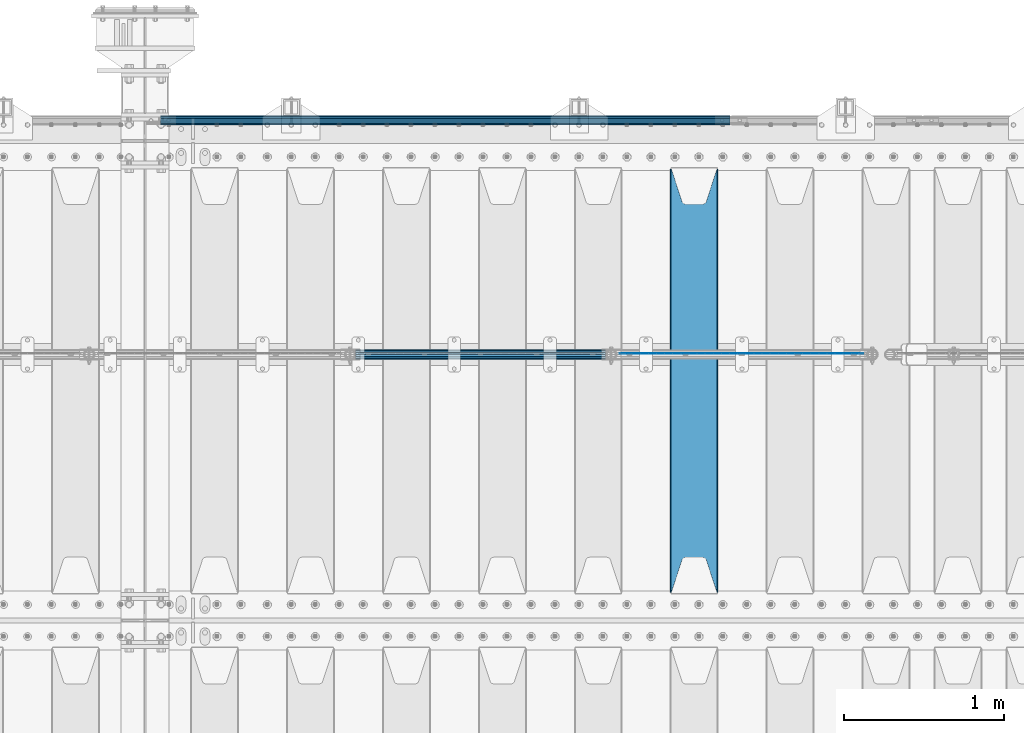
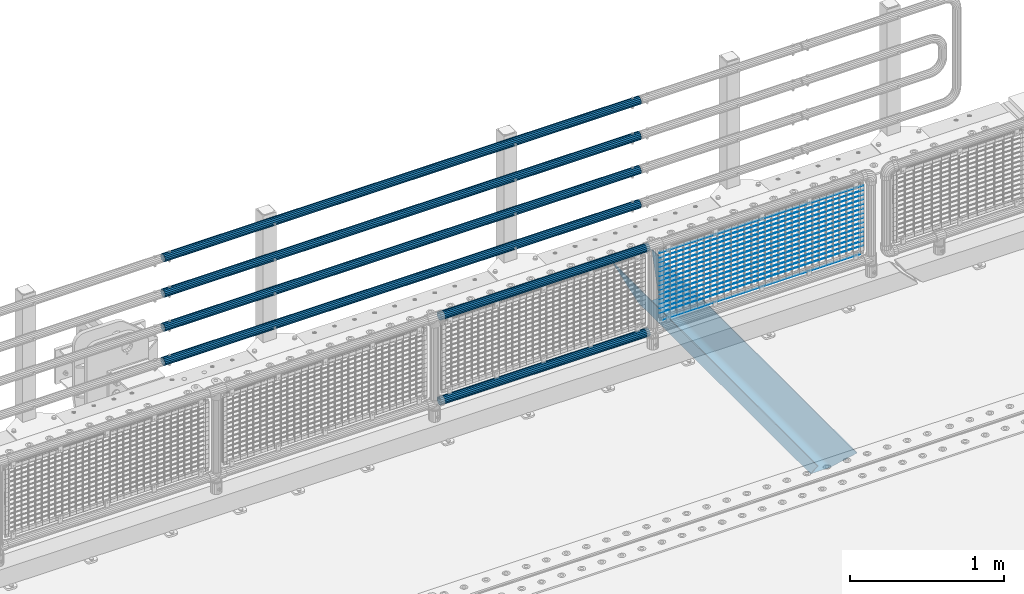
# One storey, part 146 of 270: 22 beams.
"""IFC2X3 building model written with IfcOpenShell, lengths in millimetres."""

from ifc_helpers import new_model, si_unit, frame, origin_with_axes, place, context, subcontext, project, spatial, faceted_brep, material, type_object, element, save


model = new_model("IFC2X3")

# Units and contexts
model_context = context("Model", 3, precision=1e-05, world=origin_with_axes())
body_context = subcontext(model_context, "Body", "Model", "MODEL_VIEW")
ifc_project = project(units=[si_unit("LENGTHUNIT", "METRE", prefix="MILLI"), si_unit("AREAUNIT", "SQUARE_METRE"), si_unit("VOLUMEUNIT", "CUBIC_METRE"), si_unit("MASSUNIT", "GRAM", prefix="KILO"), si_unit("TIMEUNIT", "SECOND"), si_unit("PLANEANGLEUNIT", "RADIAN"), si_unit("SOLIDANGLEUNIT", "STERADIAN"), si_unit("THERMODYNAMICTEMPERATUREUNIT", "DEGREE_CELSIUS"), si_unit("LUMINOUSINTENSITYUNIT", "LUMEN")], contexts=[model_context])

# Site, building, storey
site_placement = place(None, origin_with_axes())
site = spatial("IfcSite", under=ifc_project, at=site_placement, CompositionType="ELEMENT")
building_placement = place(site_placement, origin_with_axes())
building = spatial("IfcBuilding", under=site, at=building_placement, Name="Standard", CompositionType="ELEMENT")
storey_placement = place(building_placement, origin_with_axes())
storey = spatial("IfcBuildingStorey", under=building, at=storey_placement, Name="Undefined", CompositionType="ELEMENT", Elevation=0.0)

# Beams
ifc_material_1 = material()
beam_type_1 = type_object("IfcBeamType", PredefinedType="NOTDEFINED")
beam_1_placement = place(storey_placement, frame((17694.9999999999, -14870.1499999998, 149.849999999726), z_axis=(0.0, 0.0, -1.0), x_axis=(-1.0, 0.0, 0.0)))
element("IfcBeam", 1, at=beam_1_placement, inside=storey, type_object=beam_type_1, material=ifc_material_1, context=body_context, shape_type="Brep", body=[
    faceted_brep([(0.0, -26.5499999999993, 0.0), (0.0, -24.5290015881747, 10.1602451292931), (3563.0, -24.5290015881747, 10.1602451292931), (3563.0, -26.5499999999993, 0.0), (0.0, -18.7736850405036, 18.7736850405028), (3563.0, -18.7736850405036, 18.7736850405028), (0.0, -10.1602451292929, 24.5290015881747), (3563.0, -10.1602451292929, 24.5290015881747), (0.0, 0.0, 26.55), (3563.0, 0.0, 26.55), (0.0, 10.1602451292929, 24.5290015881747), (3563.0, 10.1602451292929, 24.5290015881747), (0.0, 18.7736850405036, 18.7736850405028), (3563.0, 18.7736850405036, 18.7736850405028), (0.0, 24.5290015881747, 10.1602451292931), (3563.0, 24.5290015881747, 10.1602451292931), (0.0, 26.5499999999993, 0.0), (3563.0, 26.5499999999993, 0.0), (0.0, 24.5290015881747, -10.1602451292931), (3563.0, 24.5290015881747, -10.1602451292931), (0.0, 18.7736850405036, -18.7736850405028), (3563.0, 18.7736850405036, -18.7736850405028), (0.0, 10.1602451292929, -24.5290015881747), (3563.0, 10.1602451292929, -24.5290015881747), (0.0, 0.0, -26.55), (3563.0, 0.0, -26.55), (0.0, -10.1602451292929, -24.5290015881747), (3563.0, -10.1602451292929, -24.5290015881747), (0.0, -18.7736850405036, -18.7736850405028), (3563.0, -18.7736850405036, -18.7736850405028), (0.0, -24.5290015881747, -10.1602451292931), (3563.0, -24.5290015881747, -10.1602451292931), (0.0, -30.1499999999996, 0.0), (0.0, -27.8549679052157, -11.5379054858058), (3563.0, -27.8549679052157, -11.5379054858075), (3563.0, -30.1499999999996, 0.0), (0.0, -21.3192694527752, -21.3192694527752), (3563.0, -21.3192694527752, -21.3192694527744), (0.0, -11.5379054858076, -27.8549679052157), (3563.0, -11.5379054858076, -27.8549679052153), (0.0, 0.0, -30.1500000000015), (3563.0, 0.0, -30.15), (0.0, 11.5379054858076, -27.8549679052157), (3563.0, 11.5379054858076, -27.8549679052153), (0.0, 21.3192694527752, -21.3192694527752), (3563.0, 21.3192694527752, -21.3192694527744), (0.0, 27.8549679052157, -11.5379054858058), (3563.0, 27.8549679052157, -11.5379054858074), (0.0, 30.1499999999996, 0.0), (3563.0, 30.1499999999996, 0.0), (0.0, 27.8549679052157, 11.5379054858058), (3563.0, 27.8549679052157, 11.5379054858075), (0.0, 21.3192694527752, 21.3192694527752), (3563.0, 21.3192694527752, 21.3192694527744), (0.0, 11.5379054858076, 27.8549679052157), (3563.0, 11.5379054858076, 27.8549679052153), (0.0, 0.0, 30.1500000000015), (3563.0, 0.0, 30.15), (0.0, -11.5379054858076, 27.8549679052157), (3563.0, -11.5379054858076, 27.8549679052153), (0.0, -21.3192694527752, 21.3192694527752), (3563.0, -21.3192694527752, 21.3192694527744), (0.0, -27.8549679052157, 11.5379054858058), (3563.0, -27.8549679052157, 11.5379054858075)], [[[0, 1, 2, 3]], [[1, 4, 5, 2]], [[4, 6, 7, 5]], [[6, 8, 9, 7]], [[8, 10, 11, 9]], [[10, 12, 13, 11]], [[12, 14, 15, 13]], [[14, 16, 17, 15]], [[16, 18, 19, 17]], [[18, 20, 21, 19]], [[20, 22, 23, 21]], [[22, 24, 25, 23]], [[24, 26, 27, 25]], [[26, 28, 29, 27]], [[28, 30, 31, 29]], [[30, 0, 3, 31]], [[32, 33, 34, 35]], [[33, 36, 37, 34]], [[36, 38, 39, 37]], [[38, 40, 41, 39]], [[40, 42, 43, 41]], [[42, 44, 45, 43]], [[44, 46, 47, 45]], [[46, 48, 49, 47]], [[48, 50, 51, 49]], [[50, 52, 53, 51]], [[52, 54, 55, 53]], [[54, 56, 57, 55]], [[56, 58, 59, 57]], [[58, 60, 61, 59]], [[60, 62, 63, 61]], [[62, 32, 35, 63]], [[37, 39, 41, 43, 45, 47, 49, 51, 53, 55, 57, 59, 61, 63, 35, 34], [5, 7, 9, 11, 13, 15, 17, 19, 21, 23, 25, 27, 29, 31, 3, 2]], [[62, 60, 58, 56, 54, 52, 50, 48, 46, 44, 42, 40, 38, 36, 33, 32], [30, 28, 26, 24, 22, 20, 18, 16, 14, 12, 10, 8, 6, 4, 1, 0]]]),
])
beam_2_placement = place(storey_placement, frame((17694.9999999999, -14870.1499999998, 420.149999999725), z_axis=(0.0, 0.0, -1.0), x_axis=(-1.0, 0.0, 0.0)))
element("IfcBeam", 2, at=beam_2_placement, inside=storey, type_object=beam_type_1, material=ifc_material_1, context=body_context, shape_type="Brep", body=[
    faceted_brep([(0.0, -26.5499999999993, 0.0), (0.0, -24.5290015881747, 10.1602451292931), (3563.0, -24.5290015881747, 10.1602451292931), (3563.0, -26.5499999999993, 0.0), (0.0, -18.7736850405036, 18.7736850405028), (3563.0, -18.7736850405036, 18.7736850405028), (0.0, -10.1602451292929, 24.5290015881747), (3563.0, -10.1602451292929, 24.5290015881747), (0.0, 0.0, 26.55), (3563.0, 0.0, 26.55), (0.0, 10.1602451292929, 24.5290015881747), (3563.0, 10.1602451292929, 24.5290015881747), (0.0, 18.7736850405036, 18.7736850405028), (3563.0, 18.7736850405036, 18.7736850405028), (0.0, 24.5290015881747, 10.1602451292931), (3563.0, 24.5290015881747, 10.1602451292931), (0.0, 26.5499999999993, 0.0), (3563.0, 26.5499999999993, 0.0), (0.0, 24.5290015881747, -10.1602451292931), (3563.0, 24.5290015881747, -10.1602451292931), (0.0, 18.7736850405036, -18.7736850405028), (3563.0, 18.7736850405036, -18.7736850405028), (0.0, 10.1602451292929, -24.5290015881747), (3563.0, 10.1602451292929, -24.5290015881747), (0.0, 0.0, -26.55), (3563.0, 0.0, -26.55), (0.0, -10.1602451292929, -24.5290015881747), (3563.0, -10.1602451292929, -24.5290015881747), (0.0, -18.7736850405036, -18.7736850405028), (3563.0, -18.7736850405036, -18.7736850405028), (0.0, -24.5290015881747, -10.1602451292931), (3563.0, -24.5290015881747, -10.1602451292931), (0.0, -30.1499999999996, 0.0), (0.0, -27.8549679052157, -11.5379054858058), (3563.0, -27.8549679052157, -11.5379054858075), (3563.0, -30.1499999999996, 0.0), (0.0, -21.3192694527752, -21.3192694527752), (3563.0, -21.3192694527752, -21.3192694527744), (0.0, -11.5379054858076, -27.8549679052157), (3563.0, -11.5379054858076, -27.8549679052153), (0.0, 0.0, -30.1500000000015), (3563.0, 0.0, -30.15), (0.0, 11.5379054858076, -27.8549679052157), (3563.0, 11.5379054858076, -27.8549679052153), (0.0, 21.3192694527752, -21.3192694527752), (3563.0, 21.3192694527752, -21.3192694527744), (0.0, 27.8549679052157, -11.5379054858058), (3563.0, 27.8549679052157, -11.5379054858074), (0.0, 30.1499999999996, 0.0), (3563.0, 30.1499999999996, 0.0), (0.0, 27.8549679052157, 11.5379054858058), (3563.0, 27.8549679052157, 11.5379054858075), (0.0, 21.3192694527752, 21.3192694527752), (3563.0, 21.3192694527752, 21.3192694527744), (0.0, 11.5379054858076, 27.8549679052157), (3563.0, 11.5379054858076, 27.8549679052153), (0.0, 0.0, 30.1500000000015), (3563.0, 0.0, 30.15), (0.0, -11.5379054858076, 27.8549679052157), (3563.0, -11.5379054858076, 27.8549679052153), (0.0, -21.3192694527752, 21.3192694527752), (3563.0, -21.3192694527752, 21.3192694527744), (0.0, -27.8549679052157, 11.5379054858058), (3563.0, -27.8549679052157, 11.5379054858075)], [[[0, 1, 2, 3]], [[1, 4, 5, 2]], [[4, 6, 7, 5]], [[6, 8, 9, 7]], [[8, 10, 11, 9]], [[10, 12, 13, 11]], [[12, 14, 15, 13]], [[14, 16, 17, 15]], [[16, 18, 19, 17]], [[18, 20, 21, 19]], [[20, 22, 23, 21]], [[22, 24, 25, 23]], [[24, 26, 27, 25]], [[26, 28, 29, 27]], [[28, 30, 31, 29]], [[30, 0, 3, 31]], [[32, 33, 34, 35]], [[33, 36, 37, 34]], [[36, 38, 39, 37]], [[38, 40, 41, 39]], [[40, 42, 43, 41]], [[42, 44, 45, 43]], [[44, 46, 47, 45]], [[46, 48, 49, 47]], [[48, 50, 51, 49]], [[50, 52, 53, 51]], [[52, 54, 55, 53]], [[54, 56, 57, 55]], [[56, 58, 59, 57]], [[58, 60, 61, 59]], [[60, 62, 63, 61]], [[62, 32, 35, 63]], [[37, 39, 41, 43, 45, 47, 49, 51, 53, 55, 57, 59, 61, 63, 35, 34], [5, 7, 9, 11, 13, 15, 17, 19, 21, 23, 25, 27, 29, 31, 3, 2]], [[62, 60, 58, 56, 54, 52, 50, 48, 46, 44, 42, 40, 38, 36, 33, 32], [30, 28, 26, 24, 22, 20, 18, 16, 14, 12, 10, 8, 6, 4, 1, 0]]]),
])
beam_3_placement = place(storey_placement, frame((17694.9999999999, -14870.1499999998, 969.849999999726), z_axis=(0.0, 0.0, -1.0), x_axis=(-1.0, 0.0, 0.0)))
element("IfcBeam", 3, at=beam_3_placement, inside=storey, type_object=beam_type_1, material=ifc_material_1, context=body_context, shape_type="Brep", body=[
    faceted_brep([(0.0, -26.5499999999993, 0.0), (0.0, -24.5290015881747, 10.1602451292931), (3563.0, -24.5290015881747, 10.1602451292931), (3563.0, -26.5499999999993, 0.0), (0.0, -18.7736850405036, 18.7736850405028), (3563.0, -18.7736850405036, 18.7736850405028), (0.0, -10.1602451292929, 24.5290015881747), (3563.0, -10.1602451292929, 24.5290015881747), (0.0, 0.0, 26.55), (3563.0, 0.0, 26.55), (0.0, 10.1602451292929, 24.5290015881747), (3563.0, 10.1602451292929, 24.5290015881747), (0.0, 18.7736850405036, 18.7736850405028), (3563.0, 18.7736850405036, 18.7736850405028), (0.0, 24.5290015881747, 10.1602451292931), (3563.0, 24.5290015881747, 10.1602451292931), (0.0, 26.5499999999993, 0.0), (3563.0, 26.5499999999993, 0.0), (0.0, 24.5290015881747, -10.1602451292931), (3563.0, 24.5290015881747, -10.1602451292931), (0.0, 18.7736850405036, -18.7736850405028), (3563.0, 18.7736850405036, -18.7736850405028), (0.0, 10.1602451292929, -24.5290015881747), (3563.0, 10.1602451292929, -24.5290015881747), (0.0, 0.0, -26.55), (3563.0, 0.0, -26.55), (0.0, -10.1602451292929, -24.5290015881747), (3563.0, -10.1602451292929, -24.5290015881747), (0.0, -18.7736850405036, -18.7736850405028), (3563.0, -18.7736850405036, -18.7736850405028), (0.0, -24.5290015881747, -10.1602451292931), (3563.0, -24.5290015881747, -10.1602451292931), (0.0, -30.1499999999996, 0.0), (0.0, -27.8549679052157, -11.5379054858058), (3563.0, -27.8549679052157, -11.5379054858075), (3563.0, -30.1499999999996, 0.0), (0.0, -21.3192694527752, -21.3192694527752), (3563.0, -21.3192694527752, -21.3192694527744), (0.0, -11.5379054858076, -27.8549679052157), (3563.0, -11.5379054858076, -27.8549679052153), (0.0, 0.0, -30.1500000000015), (3563.0, 0.0, -30.15), (0.0, 11.5379054858076, -27.8549679052157), (3563.0, 11.5379054858076, -27.8549679052153), (0.0, 21.3192694527752, -21.3192694527752), (3563.0, 21.3192694527752, -21.3192694527744), (0.0, 27.8549679052157, -11.5379054858058), (3563.0, 27.8549679052157, -11.5379054858074), (0.0, 30.1499999999996, 0.0), (3563.0, 30.1499999999996, 0.0), (0.0, 27.8549679052157, 11.5379054858058), (3563.0, 27.8549679052157, 11.5379054858075), (0.0, 21.3192694527752, 21.3192694527752), (3563.0, 21.3192694527752, 21.3192694527744), (0.0, 11.5379054858076, 27.8549679052157), (3563.0, 11.5379054858076, 27.8549679052153), (0.0, 0.0, 30.1500000000015), (3563.0, 0.0, 30.15), (0.0, -11.5379054858076, 27.8549679052157), (3563.0, -11.5379054858076, 27.8549679052153), (0.0, -21.3192694527752, 21.3192694527752), (3563.0, -21.3192694527752, 21.3192694527744), (0.0, -27.8549679052157, 11.5379054858058), (3563.0, -27.8549679052157, 11.5379054858075)], [[[0, 1, 2, 3]], [[1, 4, 5, 2]], [[4, 6, 7, 5]], [[6, 8, 9, 7]], [[8, 10, 11, 9]], [[10, 12, 13, 11]], [[12, 14, 15, 13]], [[14, 16, 17, 15]], [[16, 18, 19, 17]], [[18, 20, 21, 19]], [[20, 22, 23, 21]], [[22, 24, 25, 23]], [[24, 26, 27, 25]], [[26, 28, 29, 27]], [[28, 30, 31, 29]], [[30, 0, 3, 31]], [[32, 33, 34, 35]], [[33, 36, 37, 34]], [[36, 38, 39, 37]], [[38, 40, 41, 39]], [[40, 42, 43, 41]], [[42, 44, 45, 43]], [[44, 46, 47, 45]], [[46, 48, 49, 47]], [[48, 50, 51, 49]], [[50, 52, 53, 51]], [[52, 54, 55, 53]], [[54, 56, 57, 55]], [[56, 58, 59, 57]], [[58, 60, 61, 59]], [[60, 62, 63, 61]], [[62, 32, 35, 63]], [[37, 39, 41, 43, 45, 47, 49, 51, 53, 55, 57, 59, 61, 63, 35, 34], [5, 7, 9, 11, 13, 15, 17, 19, 21, 23, 25, 27, 29, 31, 3, 2]], [[62, 60, 58, 56, 54, 52, 50, 48, 46, 44, 42, 40, 38, 36, 33, 32], [30, 28, 26, 24, 22, 20, 18, 16, 14, 12, 10, 8, 6, 4, 1, 0]]]),
])
beam_4_placement = place(storey_placement, frame((17694.9999999999, -14870.1499999998, 689.849999999726), z_axis=(0.0, 0.0, -1.0), x_axis=(-1.0, 0.0, 0.0)))
element("IfcBeam", 4, at=beam_4_placement, inside=storey, type_object=beam_type_1, material=ifc_material_1, context=body_context, shape_type="Brep", body=[
    faceted_brep([(0.0, -26.5499999999993, 0.0), (0.0, -24.5290015881747, 10.1602451292931), (3563.0, -24.5290015881747, 10.1602451292931), (3563.0, -26.5499999999993, 0.0), (0.0, -18.7736850405036, 18.7736850405028), (3563.0, -18.7736850405036, 18.7736850405028), (0.0, -10.1602451292929, 24.5290015881747), (3563.0, -10.1602451292929, 24.5290015881747), (0.0, 0.0, 26.55), (3563.0, 0.0, 26.55), (0.0, 10.1602451292929, 24.5290015881747), (3563.0, 10.1602451292929, 24.5290015881747), (0.0, 18.7736850405036, 18.7736850405028), (3563.0, 18.7736850405036, 18.7736850405028), (0.0, 24.5290015881747, 10.1602451292931), (3563.0, 24.5290015881747, 10.1602451292931), (0.0, 26.5499999999993, 0.0), (3563.0, 26.5499999999993, 0.0), (0.0, 24.5290015881747, -10.1602451292931), (3563.0, 24.5290015881747, -10.1602451292931), (0.0, 18.7736850405036, -18.7736850405028), (3563.0, 18.7736850405036, -18.7736850405028), (0.0, 10.1602451292929, -24.5290015881747), (3563.0, 10.1602451292929, -24.5290015881747), (0.0, 0.0, -26.55), (3563.0, 0.0, -26.55), (0.0, -10.1602451292929, -24.5290015881747), (3563.0, -10.1602451292929, -24.5290015881747), (0.0, -18.7736850405036, -18.7736850405028), (3563.0, -18.7736850405036, -18.7736850405028), (0.0, -24.5290015881747, -10.1602451292931), (3563.0, -24.5290015881747, -10.1602451292931), (0.0, -30.1499999999996, 0.0), (0.0, -27.8549679052157, -11.5379054858058), (3563.0, -27.8549679052157, -11.5379054858075), (3563.0, -30.1499999999996, 0.0), (0.0, -21.3192694527752, -21.3192694527752), (3563.0, -21.3192694527752, -21.3192694527744), (0.0, -11.5379054858076, -27.8549679052157), (3563.0, -11.5379054858076, -27.8549679052153), (0.0, 0.0, -30.1500000000015), (3563.0, 0.0, -30.15), (0.0, 11.5379054858076, -27.8549679052157), (3563.0, 11.5379054858076, -27.8549679052153), (0.0, 21.3192694527752, -21.3192694527752), (3563.0, 21.3192694527752, -21.3192694527744), (0.0, 27.8549679052157, -11.5379054858058), (3563.0, 27.8549679052157, -11.5379054858074), (0.0, 30.1499999999996, 0.0), (3563.0, 30.1499999999996, 0.0), (0.0, 27.8549679052157, 11.5379054858058), (3563.0, 27.8549679052157, 11.5379054858075), (0.0, 21.3192694527752, 21.3192694527752), (3563.0, 21.3192694527752, 21.3192694527744), (0.0, 11.5379054858076, 27.8549679052157), (3563.0, 11.5379054858076, 27.8549679052153), (0.0, 0.0, 30.1500000000015), (3563.0, 0.0, 30.15), (0.0, -11.5379054858076, 27.8549679052157), (3563.0, -11.5379054858076, 27.8549679052153), (0.0, -21.3192694527752, 21.3192694527752), (3563.0, -21.3192694527752, 21.3192694527744), (0.0, -27.8549679052157, 11.5379054858058), (3563.0, -27.8549679052157, 11.5379054858075)], [[[0, 1, 2, 3]], [[1, 4, 5, 2]], [[4, 6, 7, 5]], [[6, 8, 9, 7]], [[8, 10, 11, 9]], [[10, 12, 13, 11]], [[12, 14, 15, 13]], [[14, 16, 17, 15]], [[16, 18, 19, 17]], [[18, 20, 21, 19]], [[20, 22, 23, 21]], [[22, 24, 25, 23]], [[24, 26, 27, 25]], [[26, 28, 29, 27]], [[28, 30, 31, 29]], [[30, 0, 3, 31]], [[32, 33, 34, 35]], [[33, 36, 37, 34]], [[36, 38, 39, 37]], [[38, 40, 41, 39]], [[40, 42, 43, 41]], [[42, 44, 45, 43]], [[44, 46, 47, 45]], [[46, 48, 49, 47]], [[48, 50, 51, 49]], [[50, 52, 53, 51]], [[52, 54, 55, 53]], [[54, 56, 57, 55]], [[56, 58, 59, 57]], [[58, 60, 61, 59]], [[60, 62, 63, 61]], [[62, 32, 35, 63]], [[37, 39, 41, 43, 45, 47, 49, 51, 53, 55, 57, 59, 61, 63, 35, 34], [5, 7, 9, 11, 13, 15, 17, 19, 21, 23, 25, 27, 29, 31, 3, 2]], [[62, 60, 58, 56, 54, 52, 50, 48, 46, 44, 42, 40, 38, 36, 33, 32], [30, 28, 26, 24, 22, 20, 18, 16, 14, 12, 10, 8, 6, 4, 1, 0]]]),
])
ifc_material_2 = material(Name="STEEL/S355N")
beam_type_2 = type_object("IfcBeamType", PredefinedType="NOTDEFINED")
beam_5_placement = place(storey_placement, frame((17470.0, -17825.0, -115.0), z_axis=(0.0, 0.0, 1.0), x_axis=(0.0, 1.0, 0.0)))
element("IfcBeam", 5, at=beam_5_placement, inside=storey, type_object=beam_type_2, material=ifc_material_2, context=body_context, shape_type="Brep", body=[
    faceted_brep([(0.0, 150.0, 115.0), (0.0, 143.689999999999, 115.0), (2650.00000000297, 143.689999999999, 115.0), (2650.00000000297, 150.0, 115.0), (2650.00000000297, 142.059565218398, 110.000000003096), (2650.00000000297, 148.3695652184, 110.000000003096), (2441.90079219209, -80.1103600731112, -98.0992078077845), (2437.7588105432, -77.5672621345584, -102.241189456673), (2434.06523489747, -74.4080125315522, -105.934765102404), (2430.9108609509, -70.710272125576, -109.089139048974), (2428.37322971128, -66.5649389910068, -111.626770288588), (2426.51472138055, -62.0739139532889, -113.485278619323), (2425.38102192092, -57.3475956567672, -114.618978078955), (2424.99999999987, -52.5021667386536, -115.0), (2424.99999999987, 52.5021667386536, -115.0), (2425.38102192092, 57.3475956567672, -114.618978078955), (2426.51472138055, 62.0739139532889, -113.485278619323), (2428.37322971128, 66.5649389910068, -111.626770288588), (2430.9108609509, 70.710272125576, -109.089139048974), (2434.06523489747, 74.4080125315522, -105.934765102404), (2437.7588105432, 77.5672621345584, -102.241189456673), (2441.90079219209, 80.1103600731112, -98.0992078077846), (2446.38936140511, 81.9747917625791, -93.6106385947584), (2448.2494850041, 76.2713538057251, -91.7505149957729), (2444.62967112263, 74.76777986261, -95.3703288772456), (2441.28936334126, 72.7168944282894, -98.710636658607), (2438.31067330439, 70.1691124903846, -101.689326695487), (2435.76682334747, 67.1870637758839, -104.233176652398), (2433.72034654133, 63.8440531834895, -106.279653458539), (2432.22154950042, 60.222258798236, -107.778450499454), (2431.30727574265, 56.4107117849089, -108.692724257221), (2430.99999999987, 52.5031078186876, -109.0), (2430.99999999987, -52.5031078186876, -109.0), (2431.30727574265, -56.4107117849089, -108.692724257221), (2432.22154950042, -60.222258798236, -107.778450499454), (2433.72034654133, -63.8440531834895, -106.279653458539), (2435.76682334747, -67.1870637758839, -104.233176652398), (2438.31067330438, -70.1691124903846, -101.689326695487), (2441.28936334126, -72.7168944282894, -98.7106366586071), (2444.62967112263, -74.76777986261, -95.3703288772457), (2448.2494850041, -76.2713538057251, -91.7505149957729), (2650.00000000297, -142.059565218398, 110.000000003096), (2650.00000000297, -148.3695652184, 110.000000003096), (2446.38936140511, -81.9747917625791, -93.6106385947584), (2650.00000000297, -143.689999999999, 115.0), (2650.00000000297, -150.0, 115.0), (0.0, -143.689999999999, 115.0), (0.0, -150.0, 115.0), (0.0, -148.369565218261, 110.000000002672), (203.610638597431, -81.9747917625791, -93.6106385947584), (208.099207810457, -80.1103600731112, -98.0992078077845), (212.241189459342, -77.5672621345584, -102.241189456673), (215.934765105078, -74.4080125315522, -105.934765102404), (219.089139051644, -70.710272125576, -109.089139048974), (221.626770291259, -66.5649389910068, -111.626770288588), (223.485278621993, -62.0739139532889, -113.485278619323), (224.618978081628, -57.3475956567672, -114.618978078955), (225.00000000267, -52.5021667386536, -115.0), (225.00000000267, 52.5021667386536, -115.0), (224.618978081628, 57.3475956567672, -114.618978078955), (223.485278621993, 62.0739139532889, -113.485278619323), (221.626770291259, 66.5649389910068, -111.626770288588), (219.089139051644, 70.710272125576, -109.089139048974), (215.934765105078, 74.4080125315522, -105.934765102404), (212.241189459342, 77.5672621345584, -102.241189456673), (208.099207810457, 80.1103600731112, -98.0992078077846), (203.610638597431, 81.9747917625791, -93.6106385947584), (0.0, 148.369565218261, 110.000000002672), (0.0, 142.05956521826, 110.000000002672), (201.750514998446, 76.2713538057251, -91.7505149957729), (205.370328879915, 74.76777986261, -95.3703288772456), (208.710636661279, 72.7168944282894, -98.710636658607), (211.689326698157, 70.1691124903846, -101.689326695487), (214.233176655071, 67.1870637758839, -104.233176652398), (216.27965346121, 63.8440531834895, -106.279653458539), (217.778450502126, 60.222258798236, -107.778450499454), (218.692724259894, 56.4107117849089, -108.692724257221), (219.00000000267, 52.5031078186876, -109.0), (219.00000000267, -52.5031078186876, -109.0), (218.692724259894, -56.4107117849089, -108.692724257221), (217.778450502123, -60.222258798236, -107.778450499454), (216.27965346121, -63.8440531834895, -106.279653458539), (214.233176655071, -67.1870637758839, -104.233176652398), (211.689326698157, -70.1691124903846, -101.689326695487), (208.710636661279, -72.7168944282894, -98.7106366586071), (205.370328879915, -74.76777986261, -95.3703288772457), (201.750514998446, -76.2713538057251, -91.7505149957729), (0.0, -142.05956521826, 110.000000002672)], [[[0, 1, 2, 3]], [[3, 2, 4, 5]], [[6, 7, 8, 9, 10, 11, 12, 13, 14, 15, 16, 17, 18, 19, 20, 21, 22, 5, 4, 23, 24, 25, 26, 27, 28, 29, 30, 31, 32, 33, 34, 35, 36, 37, 38, 39, 40, 41, 42, 43]], [[44, 45, 42, 41]], [[46, 47, 45, 44]], [[43, 42, 45, 47, 48, 49]], [[6, 43, 49, 50]], [[7, 6, 50, 51]], [[8, 7, 51, 52]], [[9, 8, 52, 53]], [[10, 9, 53, 54]], [[11, 10, 54, 55]], [[12, 11, 55, 56]], [[13, 12, 56, 57]], [[14, 13, 57, 58]], [[15, 14, 58, 59]], [[16, 15, 59, 60]], [[17, 16, 60, 61]], [[18, 17, 61, 62]], [[19, 18, 62, 63]], [[20, 19, 63, 64]], [[21, 20, 64, 65]], [[22, 21, 65, 66]], [[0, 3, 5, 22, 66, 67]], [[1, 0, 67, 68]], [[23, 4, 2, 1, 68, 69]], [[24, 23, 69, 70]], [[25, 24, 70, 71]], [[26, 25, 71, 72]], [[27, 26, 72, 73]], [[28, 27, 73, 74]], [[29, 28, 74, 75]], [[30, 29, 75, 76]], [[31, 30, 76, 77]], [[32, 31, 77, 78]], [[33, 32, 78, 79]], [[34, 33, 79, 80]], [[35, 34, 80, 81]], [[36, 35, 81, 82]], [[37, 36, 82, 83]], [[38, 37, 83, 84]], [[39, 38, 84, 85]], [[40, 39, 85, 86]], [[46, 44, 41, 40, 86, 87]], [[47, 46, 87, 48]], [[86, 85, 84, 83, 82, 81, 80, 79, 78, 77, 76, 75, 74, 73, 72, 71, 70, 69, 68, 67, 66, 65, 64, 63, 62, 61, 60, 59, 58, 57, 56, 55, 54, 53, 52, 51, 50, 49, 48, 87]]]),
])
ifc_material_3 = material(Name="Misc_Undefined")
beam_type_3 = type_object("IfcBeamType", Name="D3", PredefinedType="NOTDEFINED")
for number, where, z_axis, x_axis in (
    (6, (17006.0, -16329.5, 851.596999999999), (0.0, 0.0, 1.0), (1.0, 0.0, 0.0)),
    (7, (17006.0, -16329.5, 669.452), (0.0, 0.0, 1.0), (1.0, 0.0, 0.0)),
    (8, (17006.0, -16329.5, 523.736), (0.0, 0.0, 1.0), (1.0, 0.0, 0.0)),
    (9, (17006.0, -16329.5, 487.307), (0.0, 0.0, 1.0), (1.0, 0.0, 0.0)),
    (10, (17006.0, -16329.5, 705.881), (0.0, 0.0, 1.0), (1.0, 0.0, 0.0)),
    (11, (17006.0, -16329.5, 596.594), (0.0, 0.0, 1.0), (1.0, 0.0, 0.0)),
    (12, (17006.0, -16329.5, 450.878), (0.0, 0.0, 1.0), (1.0, 0.0, 0.0)),
    (13, (17006.0, -16329.5, 815.167999999999), (0.0, 0.0, 1.0), (1.0, 0.0, 0.0)),
    (14, (17006.0, -16329.5, 888.025999999999), (0.0, 0.0, 1.0), (1.0, 0.0, 0.0)),
    (15, (17006.0, -16329.5, 778.738999999999), (0.0, 0.0, 1.0), (1.0, 0.0, 0.0)),
    (16, (17006.0, -16329.5, 742.309999999999), (0.0, 0.0, 1.0), (1.0, 0.0, 0.0)),
    (17, (17006.0, -16329.5, 633.023), (0.0, 0.0, 1.0), (1.0, 0.0, 0.0)),
    (18, (17006.0, -16329.5, 560.165), (0.0, 0.0, 1.0), (1.0, 0.0, 0.0)),
    (19, (17006.0, -16329.5, 414.449), (0.0, 0.0, 1.0), (1.0, 0.0, 0.0)),
):
    element("IfcBeam", number, at=place(storey_placement, frame(where, z_axis=z_axis, x_axis=x_axis)), inside=storey, type_object=beam_type_3, material=ifc_material_3, ObjectType="D3", context=body_context, shape_type="Brep", body=[
        faceted_brep([(0.0, -1.5, 0.0), (0.0, -0.75, -1.29903810567669), (1523.0, -0.75, -1.29903810567669), (1523.0, -1.5, 0.0), (0.0, 0.75, -1.29903810567669), (1523.0, 0.75, -1.29903810567669), (0.0, 1.5, 0.0), (1523.0, 1.5, 0.0), (0.0, 0.75, 1.29903810567669), (1523.0, 0.75, 1.29903810567669), (0.0, -0.75, 1.29903810567669), (1523.0, -0.75, 1.29903810567669)], [[[0, 1, 2, 3]], [[1, 4, 5, 2]], [[4, 6, 7, 5]], [[6, 8, 9, 7]], [[8, 10, 11, 9]], [[10, 0, 3, 11]], [[5, 7, 9, 11, 3, 2]], [[10, 8, 6, 4, 1, 0]]]),
    ])
beam_6_placement = place(storey_placement, frame((17031.0, -16329.5, 353.02), z_axis=(0.0, 0.0, 1.0), x_axis=(1.0, 0.0, 0.0)))
element("IfcBeam", 20, at=beam_6_placement, inside=storey, type_object=beam_type_3, material=ifc_material_3, ObjectType="D3", context=body_context, shape_type="Brep", body=[
    faceted_brep([(0.0, -1.5, 0.0), (0.0, -0.75, -1.29903810567669), (1473.0, -0.75, -1.29903810567669), (1473.0, -1.5, 0.0), (0.0, 0.75, -1.29903810567669), (1473.0, 0.75, -1.29903810567663), (0.0, 1.5, 0.0), (1473.0, 1.5, 0.0), (0.0, 0.75, 1.29903810567669), (1473.0, 0.75, 1.29903810567669), (0.0, -0.75, 1.29903810567669), (1473.0, -0.75, 1.29903810567669)], [[[0, 1, 2, 3]], [[1, 4, 5, 2]], [[4, 6, 7, 5]], [[6, 8, 9, 7]], [[8, 10, 11, 9]], [[10, 0, 3, 11]], [[5, 7, 9, 11, 3, 2]], [[10, 8, 6, 4, 1, 0]]]),
])
beam_type_4 = type_object("IfcBeamType", PredefinedType="NOTDEFINED")
beam_7_placement = place(storey_placement, frame((15352.85, -16335.5, 969.849999999999), z_axis=(0.0, 0.0, 1.0), x_axis=(1.0, 0.0, 0.0)))
element("IfcBeam", 21, at=beam_7_placement, inside=storey, type_object=beam_type_4, material=ifc_material_1, context=body_context, shape_type="Brep", body=[
    faceted_brep([(0.0, -25.3500000000004, 0.0), (0.0, -23.4203461491616, 9.70102501045403), (1563.0, -23.4203461491616, 9.70102501045506), (1563.0, -25.3500000000004, 0.0), (0.0, -17.9251569030785, 17.9251569030785), (1563.0, -17.9251569030785, 17.925156903079), (0.0, -9.70102501045585, 23.4203461491597), (1563.0, -9.70102501045585, 23.4203461491611), (0.0, 0.0, 25.3499999999985), (1563.0, 0.0, 25.35), (0.0, 9.70102501045585, 23.4203461491597), (1563.0, 9.70102501045585, 23.4203461491611), (0.0, 17.9251569030785, 17.9251569030785), (1563.0, 17.9251569030785, 17.925156903079), (0.0, 23.4203461491616, 9.70102501045403), (1563.0, 23.4203461491616, 9.70102501045506), (0.0, 25.3500000000004, 0.0), (1563.0, 25.3500000000004, 0.0), (0.0, 23.4203461491616, -9.70102501045403), (1563.0, 23.4203461491616, -9.70102501045506), (0.0, 17.9251569030785, -17.9251569030785), (1563.0, 17.9251569030785, -17.925156903079), (0.0, 9.70102501045585, -23.4203461491597), (1563.0, 9.70102501045585, -23.4203461491611), (0.0, 0.0, -25.3499999999985), (1563.0, 0.0, -25.35), (0.0, -9.70102501045585, -23.4203461491597), (1563.0, -9.70102501045585, -23.4203461491611), (0.0, -17.9251569030785, -17.9251569030785), (1563.0, -17.9251569030785, -17.925156903079), (0.0, -23.4203461491616, -9.70102501045403), (1563.0, -23.4203461491616, -9.70102501045506), (0.0, -30.1499999999996, 0.0), (0.0, -27.8549679052157, -11.5379054858058), (1563.0, -27.8549679052157, -11.5379054858075), (1563.0, -30.1499999999996, 0.0), (0.0, -21.3192694527752, -21.3192694527752), (1563.0, -21.3192694527752, -21.3192694527744), (0.0, -11.5379054858076, -27.8549679052157), (1563.0, -11.5379054858076, -27.8549679052153), (0.0, 0.0, -30.1500000000015), (1563.0, 0.0, -30.15), (0.0, 11.5379054858076, -27.8549679052157), (1563.0, 11.5379054858076, -27.8549679052153), (0.0, 21.3192694527752, -21.3192694527752), (1563.0, 21.3192694527752, -21.3192694527744), (0.0, 27.8549679052157, -11.5379054858058), (1563.0, 27.8549679052157, -11.5379054858074), (0.0, 30.1499999999996, 0.0), (1563.0, 30.1499999999996, 0.0), (0.0, 27.8549679052157, 11.5379054858058), (1563.0, 27.8549679052157, 11.5379054858074), (0.0, 21.3192694527752, 21.3192694527752), (1563.0, 21.3192694527752, 21.3192694527744), (0.0, 11.5379054858076, 27.8549679052157), (1563.0, 11.5379054858076, 27.8549679052153), (0.0, 0.0, 30.1500000000015), (1563.0, 0.0, 30.15), (0.0, -11.5379054858076, 27.8549679052157), (1563.0, -11.5379054858076, 27.8549679052153), (0.0, -21.3192694527752, 21.3192694527752), (1563.0, -21.3192694527752, 21.3192694527744), (0.0, -27.8549679052157, 11.5379054858058), (1563.0, -27.8549679052157, 11.5379054858074)], [[[0, 1, 2, 3]], [[1, 4, 5, 2]], [[4, 6, 7, 5]], [[6, 8, 9, 7]], [[8, 10, 11, 9]], [[10, 12, 13, 11]], [[12, 14, 15, 13]], [[14, 16, 17, 15]], [[16, 18, 19, 17]], [[18, 20, 21, 19]], [[20, 22, 23, 21]], [[22, 24, 25, 23]], [[24, 26, 27, 25]], [[26, 28, 29, 27]], [[28, 30, 31, 29]], [[30, 0, 3, 31]], [[32, 33, 34, 35]], [[33, 36, 37, 34]], [[36, 38, 39, 37]], [[38, 40, 41, 39]], [[40, 42, 43, 41]], [[42, 44, 45, 43]], [[44, 46, 47, 45]], [[46, 48, 49, 47]], [[48, 50, 51, 49]], [[50, 52, 53, 51]], [[52, 54, 55, 53]], [[54, 56, 57, 55]], [[56, 58, 59, 57]], [[58, 60, 61, 59]], [[60, 62, 63, 61]], [[62, 32, 35, 63]], [[37, 39, 41, 43, 45, 47, 49, 51, 53, 55, 57, 59, 61, 63, 35, 34], [5, 7, 9, 11, 13, 15, 17, 19, 21, 23, 25, 27, 29, 31, 3, 2]], [[62, 60, 58, 56, 54, 52, 50, 48, 46, 44, 42, 40, 38, 36, 33, 32], [30, 28, 26, 24, 22, 20, 18, 16, 14, 12, 10, 8, 6, 4, 1, 0]]]),
])
beam_8_placement = place(storey_placement, frame((15352.85, -16335.5, 298.170000000001), z_axis=(0.0, 0.0, 1.0), x_axis=(1.0, 0.0, 0.0)))
element("IfcBeam", 22, at=beam_8_placement, inside=storey, type_object=beam_type_4, material=ifc_material_1, context=body_context, shape_type="Brep", body=[
    faceted_brep([(0.0, -25.3500000000004, 0.0), (0.0, -23.4203461491616, 9.70102501045403), (1563.0, -23.4203461491616, 9.70102501045506), (1563.0, -25.3500000000004, 0.0), (0.0, -17.9251569030785, 17.9251569030785), (1563.0, -17.9251569030785, 17.925156903079), (0.0, -9.70102501045585, 23.4203461491597), (1563.0, -9.70102501045585, 23.4203461491611), (0.0, 0.0, 25.3499999999985), (1563.0, 0.0, 25.35), (0.0, 9.70102501045585, 23.4203461491597), (1563.0, 9.70102501045585, 23.4203461491611), (0.0, 17.9251569030785, 17.9251569030785), (1563.0, 17.9251569030785, 17.925156903079), (0.0, 23.4203461491616, 9.70102501045403), (1563.0, 23.4203461491616, 9.70102501045506), (0.0, 25.3500000000004, 0.0), (1563.0, 25.3500000000004, 0.0), (0.0, 23.4203461491616, -9.70102501045403), (1563.0, 23.4203461491616, -9.70102501045506), (0.0, 17.9251569030785, -17.9251569030785), (1563.0, 17.9251569030785, -17.925156903079), (0.0, 9.70102501045585, -23.4203461491597), (1563.0, 9.70102501045585, -23.4203461491611), (0.0, 0.0, -25.3499999999985), (1563.0, 0.0, -25.35), (0.0, -9.70102501045585, -23.4203461491597), (1563.0, -9.70102501045585, -23.4203461491611), (0.0, -17.9251569030785, -17.9251569030785), (1563.0, -17.9251569030785, -17.925156903079), (0.0, -23.4203461491616, -9.70102501045403), (1563.0, -23.4203461491616, -9.70102501045506), (0.0, -30.1499999999996, 0.0), (0.0, -27.8549679052157, -11.5379054858058), (1563.0, -27.8549679052157, -11.5379054858075), (1563.0, -30.1499999999996, 0.0), (0.0, -21.3192694527752, -21.3192694527752), (1563.0, -21.3192694527752, -21.3192694527744), (0.0, -11.5379054858076, -27.8549679052157), (1563.0, -11.5379054858076, -27.8549679052153), (0.0, 0.0, -30.1500000000015), (1563.0, 0.0, -30.15), (0.0, 11.5379054858076, -27.8549679052157), (1563.0, 11.5379054858076, -27.8549679052153), (0.0, 21.3192694527752, -21.3192694527752), (1563.0, 21.3192694527752, -21.3192694527744), (0.0, 27.8549679052157, -11.5379054858058), (1563.0, 27.8549679052157, -11.5379054858074), (0.0, 30.1499999999996, 0.0), (1563.0, 30.1499999999996, 0.0), (0.0, 27.8549679052157, 11.5379054858058), (1563.0, 27.8549679052157, 11.5379054858074), (0.0, 21.3192694527752, 21.3192694527752), (1563.0, 21.3192694527752, 21.3192694527744), (0.0, 11.5379054858076, 27.8549679052157), (1563.0, 11.5379054858076, 27.8549679052153), (0.0, 0.0, 30.1500000000015), (1563.0, 0.0, 30.15), (0.0, -11.5379054858076, 27.8549679052157), (1563.0, -11.5379054858076, 27.8549679052153), (0.0, -21.3192694527752, 21.3192694527752), (1563.0, -21.3192694527752, 21.3192694527744), (0.0, -27.8549679052157, 11.5379054858058), (1563.0, -27.8549679052157, 11.5379054858074)], [[[0, 1, 2, 3]], [[1, 4, 5, 2]], [[4, 6, 7, 5]], [[6, 8, 9, 7]], [[8, 10, 11, 9]], [[10, 12, 13, 11]], [[12, 14, 15, 13]], [[14, 16, 17, 15]], [[16, 18, 19, 17]], [[18, 20, 21, 19]], [[20, 22, 23, 21]], [[22, 24, 25, 23]], [[24, 26, 27, 25]], [[26, 28, 29, 27]], [[28, 30, 31, 29]], [[30, 0, 3, 31]], [[32, 33, 34, 35]], [[33, 36, 37, 34]], [[36, 38, 39, 37]], [[38, 40, 41, 39]], [[40, 42, 43, 41]], [[42, 44, 45, 43]], [[44, 46, 47, 45]], [[46, 48, 49, 47]], [[48, 50, 51, 49]], [[50, 52, 53, 51]], [[52, 54, 55, 53]], [[54, 56, 57, 55]], [[56, 58, 59, 57]], [[58, 60, 61, 59]], [[60, 62, 63, 61]], [[62, 32, 35, 63]], [[37, 39, 41, 43, 45, 47, 49, 51, 53, 55, 57, 59, 61, 63, 35, 34], [5, 7, 9, 11, 13, 15, 17, 19, 21, 23, 25, 27, 29, 31, 3, 2]], [[62, 60, 58, 56, 54, 52, 50, 48, 46, 44, 42, 40, 38, 36, 33, 32], [30, 28, 26, 24, 22, 20, 18, 16, 14, 12, 10, 8, 6, 4, 1, 0]]]),
])

save(model, "model.ifc")
